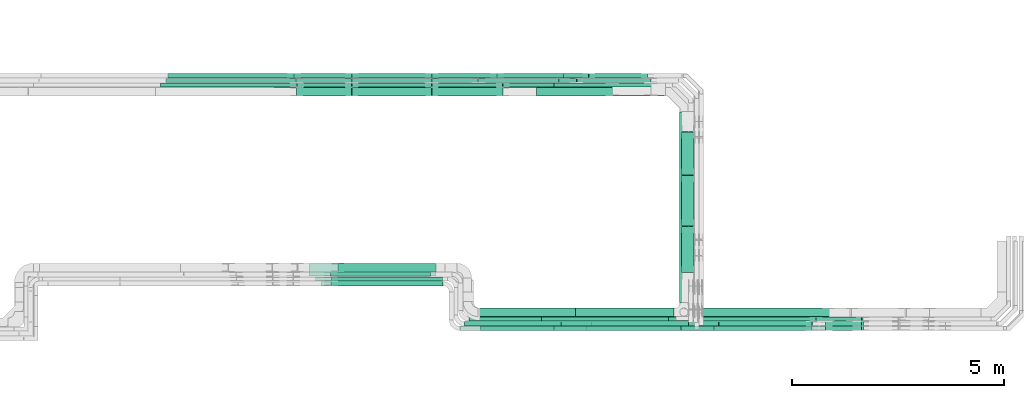
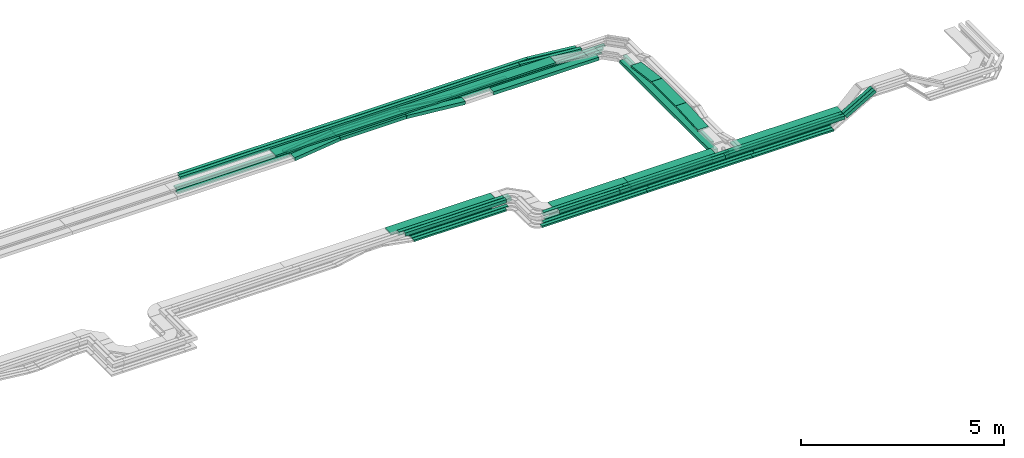
# One storey, part 4 of 33: 63 flow segments.
"""IFC2X3 building model written with IfcOpenShell, lengths in millimetres."""

from ifc_helpers import new_model, entity, si_unit, converted_unit, derived_unit, direction, frame, frame_2d, origin, origin_2d_with_axis, place, context, subcontext, project, spatial, rectangle, extrude, type_object, element, save


model = new_model("IFC2X3")

# Units and contexts
model_context = context("Model", 3, precision=0.01, world=origin(), true_north=direction((6.12303176911189e-17, 1.0)))
body_context = subcontext(model_context, "Body", "Model", "MODEL_VIEW")
ifc_project = project(units=[si_unit("LENGTHUNIT", "METRE", prefix="MILLI"), si_unit("AREAUNIT", "SQUARE_METRE"), si_unit("VOLUMEUNIT", "CUBIC_METRE"), converted_unit("PLANEANGLEUNIT", "DEGREE", entity("IfcRatioMeasure", 0.0174532925199433), si_unit("PLANEANGLEUNIT", "RADIAN"), dimensions=[0, 0, 0, 0, 0, 0, 0]), si_unit("MASSUNIT", "GRAM", prefix="KILO"), derived_unit("MASSDENSITYUNIT", [(si_unit("MASSUNIT", "GRAM", prefix="KILO"), 1), (si_unit("LENGTHUNIT", "METRE"), -3)]), derived_unit("MOMENTOFINERTIAUNIT", [(si_unit("LENGTHUNIT", "METRE"), 4)]), si_unit("TIMEUNIT", "SECOND"), si_unit("FREQUENCYUNIT", "HERTZ"), si_unit("THERMODYNAMICTEMPERATUREUNIT", "DEGREE_CELSIUS"), derived_unit("THERMALTRANSMITTANCEUNIT", [(si_unit("MASSUNIT", "GRAM", prefix="KILO"), 1), (si_unit("THERMODYNAMICTEMPERATUREUNIT", "KELVIN"), -1), (si_unit("TIMEUNIT", "SECOND"), -3)]), derived_unit("VOLUMETRICFLOWRATEUNIT", [(si_unit("LENGTHUNIT", "METRE"), 3), (si_unit("TIMEUNIT", "SECOND"), -1)]), derived_unit("MASSFLOWRATEUNIT", [(si_unit("MASSUNIT", "GRAM", prefix="KILO"), 1), (si_unit("TIMEUNIT", "SECOND"), -1)]), derived_unit("ROTATIONALFREQUENCYUNIT", [(si_unit("TIMEUNIT", "SECOND"), -1)]), si_unit("ELECTRICCURRENTUNIT", "AMPERE"), si_unit("ELECTRICVOLTAGEUNIT", "VOLT"), si_unit("POWERUNIT", "WATT"), si_unit("FORCEUNIT", "NEWTON", prefix="KILO"), si_unit("ILLUMINANCEUNIT", "LUX"), si_unit("LUMINOUSFLUXUNIT", "LUMEN"), si_unit("LUMINOUSINTENSITYUNIT", "CANDELA"), derived_unit("USERDEFINED", [(si_unit("MASSUNIT", "GRAM", prefix="KILO"), -1), (si_unit("LENGTHUNIT", "METRE"), -2), (si_unit("TIMEUNIT", "SECOND"), 3), (si_unit("LUMINOUSFLUXUNIT", "LUMEN"), 1)]), derived_unit("LINEARVELOCITYUNIT", [(si_unit("LENGTHUNIT", "METRE"), 1), (si_unit("TIMEUNIT", "SECOND"), -1)]), si_unit("PRESSUREUNIT", "PASCAL"), derived_unit("USERDEFINED", [(si_unit("LENGTHUNIT", "METRE"), -2), (si_unit("MASSUNIT", "GRAM", prefix="KILO"), 1), (si_unit("TIMEUNIT", "SECOND"), -2)]), derived_unit("LINEARFORCEUNIT", [(si_unit("MASSUNIT", "GRAM", prefix="KILO"), 1), (si_unit("LENGTHUNIT", "METRE"), 1), (si_unit("TIMEUNIT", "SECOND"), -2), (si_unit("LENGTHUNIT", "METRE"), -1)]), derived_unit("PLANARFORCEUNIT", [(si_unit("MASSUNIT", "GRAM", prefix="KILO"), 1), (si_unit("LENGTHUNIT", "METRE"), 1), (si_unit("TIMEUNIT", "SECOND"), -2), (si_unit("LENGTHUNIT", "METRE"), -2)])], contexts=[model_context])

# Site, building, storey
site_placement = place(None, frame((0.0, -0.00077364408347762, 0.0)))
site = spatial("IfcSite", under=ifc_project, at=site_placement, CompositionType="ELEMENT")
building_placement = place(site_placement, origin())
building = spatial("IfcBuilding", under=site, at=building_placement, CompositionType="ELEMENT")
storey_placement = place(building_placement, frame((0.0, 0.0, 8100.0)))
storey = spatial("IfcBuildingStorey", under=building, at=storey_placement, CompositionType="ELEMENT", Elevation=8100.0)

# Flow segments
cable_carrier_segment_type = type_object("IfcCableCarrierSegmentType", PredefinedType="CABLETRAYSEGMENT")
flow_segment_1_placement = place(storey_placement, frame((56885.3785328742, 14174.4992263554, 2549.99987589612)))
element("IfcFlowSegment", 1, at=flow_segment_1_placement, inside=storey, type_object=cable_carrier_segment_type, context=body_context, shape_type="SweptSolid", body=[
    extrude(rectangle(XDim=2998.73000000511, YDim=199.999999999998, at=frame_2d((0.0, -1.08002495835535e-12), x_axis=(1.0, 0.0))), frame((1499.36500000255, 100.0, 6.20517646780172e-05)), (0.0, 0.0, 1.0), 100.000000000001),
])
flow_segment_2_placement = place(storey_placement, frame((60470.1085349485, 9693.59904322263, 2550.0)))
element("IfcFlowSegment", 2, at=flow_segment_2_placement, inside=storey, type_object=cable_carrier_segment_type, context=body_context, shape_type="SweptSolid", body=[
    extrude(rectangle(XDim=4312.67919252471, YDim=99.9999999999946, at=frame_2d((1.13686837721616e-12, 4.33075797445781e-12), x_axis=(1.0, 0.0))), frame((50.0, 2156.33959626235, 0.0), z_axis=(0.0, 0.0, 1.0), x_axis=(0.0, -1.0, 0.0)), (0.0, 0.0, 1.0), 50.0000000000038),
])
flow_segment_3_placement = place(storey_placement, frame((59995.4041032348, 8859.97860618821, 2549.87332137859)))
element("IfcFlowSegment", 3, at=flow_segment_3_placement, inside=storey, type_object=cable_carrier_segment_type, context=body_context, shape_type="SweptSolid", body=[
    extrude(rectangle(XDim=3477.62186927145, YDim=99.9999999999989, at=frame_2d((-4.32009983342141e-12, 5.40012479177676e-13), x_axis=(1.0, 0.0))), frame((1738.81093463572, 50.0, 0.0), z_axis=(0.0, 0.0, 1.0), x_axis=(-1.0, 0.0, 0.0)), (0.0, 0.0, 1.0), 50.0000000000016),
])
flow_segment_4_placement = place(storey_placement, frame((60590.1085349485, 8969.97860618816, 2549.83876380786)))
element("IfcFlowSegment", 4, at=flow_segment_4_placement, inside=storey, type_object=cable_carrier_segment_type, context=body_context, shape_type="SweptSolid", body=[
    extrude(rectangle(XDim=3207.0799274972, YDim=200.0, at=frame_2d((4.32009983342141e-12, -5.47117906535277e-13), x_axis=(1.0, 0.0))), frame((1603.5399637486, 100.0, 0.0)), (0.0, 0.0, 1.0), 99.9999999999989),
])
flow_segment_5_placement = place(storey_placement, frame((63706.7154942404, 8749.97860609501, 2814.44529768495)))
element("IfcFlowSegment", 5, at=flow_segment_5_placement, inside=storey, type_object=cable_carrier_segment_type, context=body_context, shape_type="SweptSolid", body=[
    extrude(rectangle(XDim=99.9999999999999, YDim=99.9999999999989, at=frame_2d((4.03943545279617e-12, 0.0), x_axis=(1.0, 0.0))), frame((25.0, 50.0, 43.3012701916263), z_axis=(0.866025403784404, 0.0, 0.50000000000006), x_axis=(-0.50000000000006, 0.0, 0.866025403784404)), (0.0, 0.0, 1.0), 967.734125088294),
])
flow_segment_6_placement = place(storey_placement, frame((63705.8163687415, 8639.97859022198, 2813.92618733611)))
element("IfcFlowSegment", 6, at=flow_segment_6_placement, inside=storey, type_object=cable_carrier_segment_type, context=body_context, shape_type="SweptSolid", body=[
    extrude(rectangle(XDim=100.000000000006, YDim=99.9999999999999, at=frame_2d((-9.41469124882133e-13, 0.0), x_axis=(1.0, 0.0))), frame((25.0000652674196, 50.0, 43.3013078713806), z_axis=(0.866025403783436, 1.50728637734173e-06, 0.499999999999464), x_axis=(-0.500000000000032, 0.0, 0.86602540378442)), (0.0, 0.0, 1.0), 970.372264991507),
])
flow_segment_7_placement = place(storey_placement, frame((63476.8919979099, 8859.97860618821, 2557.60794957423)))
element("IfcFlowSegment", 7, at=flow_segment_7_placement, inside=storey, type_object=cable_carrier_segment_type, context=body_context, shape_type="SweptSolid", body=[
    extrude(rectangle(XDim=49.9999999999919, YDim=99.9999999999989, at=frame_2d((0.0, 3.75166564481333e-12), x_axis=(0.0, 1.0))), frame((12.5000000000058, 50.0, 21.6506350946079), z_axis=(0.866025403784457, 0.0, 0.499999999999968), x_axis=(0.0, 1.0, 0.0)), (0.0, 0.0, 1.0), 1241.85824337273),
])
flow_segment_8_placement = place(storey_placement, frame((55181.108534959, 8749.97860618822, 2549.86934553522)))
element("IfcFlowSegment", 8, at=flow_segment_8_placement, inside=storey, type_object=cable_carrier_segment_type, context=body_context, shape_type="SweptSolid", body=[
    extrude(rectangle(XDim=2998.73000000509, YDim=99.9999999999989, at=origin_2d_with_axis()), frame((1499.36500000254, 50.0, 0.0)), (0.0, 0.0, 1.0), 49.9999999999995),
])
flow_segment_9_placement = place(storey_placement, frame((55071.108534959, 8639.98005285077, 2548.15905189632)))
element("IfcFlowSegment", 9, at=flow_segment_9_placement, inside=storey, type_object=cable_carrier_segment_type, context=body_context, shape_type="SweptSolid", body=[
    extrude(rectangle(XDim=2998.73000000509, YDim=100.000000000001, at=origin_2d_with_axis()), frame((1499.36500000254, 50.0, 0.0)), (0.0, 0.0, 1.0), 49.9999999999995),
])
flow_segment_10_placement = place(storey_placement, frame((52023.1966318499, 9914.99937591541, 2549.87332137861)))
element("IfcFlowSegment", 10, at=flow_segment_10_placement, inside=storey, type_object=cable_carrier_segment_type, context=body_context, shape_type="SweptSolid", body=[
    extrude(rectangle(XDim=2356.3241779721, YDim=99.9999999999989, at=frame_2d((4.32009983342141e-12, 1.08357767203415e-12), x_axis=(1.0, 0.0))), frame((1178.16208898605, 50.0, 0.0), z_axis=(0.0, 0.0, 1.0), x_axis=(-1.0, 0.0, 0.0)), (0.0, 0.0, 1.0), 50.0000000000016),
])
flow_segment_11_placement = place(storey_placement, frame((52525.1367458162, 14174.499226356, 2704.57872565433)))
element("IfcFlowSegment", 11, at=flow_segment_11_placement, inside=storey, type_object=cable_carrier_segment_type, context=body_context, shape_type="SweptSolid", body=[
    extrude(rectangle(XDim=1876.86289906557, YDim=200.000000000002, at=origin_2d_with_axis()), frame((938.431449532787, 100.0, 0.0)), (0.0, 0.0, 1.0), 99.9999999999989),
])
flow_segment_12_placement = place(storey_placement, frame((57297.1754327757, 14382.2782357473, 2550.0)))
element("IfcFlowSegment", 12, at=flow_segment_12_placement, inside=storey, type_object=cable_carrier_segment_type, context=body_context, shape_type="SweptSolid", body=[
    extrude(rectangle(XDim=2796.93310217293, YDim=99.9999999999989, at=frame_2d((0.0, 1.08357767203415e-12), x_axis=(1.0, 0.0))), frame((1398.46655108647, 50.0, 0.0), z_axis=(0.0, 0.0, 1.0), x_axis=(-1.0, 0.0, 0.0)), (0.0, 0.0, 1.0), 49.9999999999995),
])
flow_segment_13_placement = place(storey_placement, frame((57517.1754327757, 14602.2782357473, 2550.0)))
element("IfcFlowSegment", 13, at=flow_segment_13_placement, inside=storey, type_object=cable_carrier_segment_type, context=body_context, shape_type="SweptSolid", body=[
    extrude(rectangle(XDim=2796.93310217294, YDim=99.9999999999989, at=frame_2d((4.43378667114303e-12, 1.08357767203415e-12), x_axis=(1.0, 0.0))), frame((1398.46655108647, 50.0, 0.0), z_axis=(0.0, 0.0, 1.0), x_axis=(-1.0, 0.0, 0.0)), (0.0, 0.0, 1.0), 50.0000000000016),
])
flow_segment_14_placement = place(storey_placement, frame((52523.6443090049, 14382.2782357473, 2704.02706365648)))
element("IfcFlowSegment", 14, at=flow_segment_14_placement, inside=storey, type_object=cable_carrier_segment_type, context=body_context, shape_type="SweptSolid", body=[
    extrude(rectangle(XDim=1879.49381672388, YDim=99.9999999999989, at=frame_2d((-4.32009983342141e-12, 0.0), x_axis=(1.0, 0.0))), frame((939.746908361942, 50.0, 0.0), z_axis=(0.0, 0.0, 1.0), x_axis=(-1.0, 0.0, 0.0)), (0.0, 0.0, 1.0), 50.0000000000016),
])
flow_segment_15_placement = place(storey_placement, frame((52525.6197642825, 14492.2782357474, 2704.02285746088)))
element("IfcFlowSegment", 15, at=flow_segment_15_placement, inside=storey, type_object=cable_carrier_segment_type, context=body_context, shape_type="SweptSolid", body=[
    extrude(rectangle(XDim=1881.17742834909, YDim=99.9999999999989, at=origin_2d_with_axis()), frame((940.588714174547, 50.0, 0.0), z_axis=(0.0, 0.0, 1.0), x_axis=(-1.0, 0.0, 0.0)), (0.0, 0.0, 1.0), 50.0000000000016),
])
flow_segment_16_placement = place(storey_placement, frame((52523.5605083253, 14602.2782357473, 2704.50214316131)))
element("IfcFlowSegment", 16, at=flow_segment_16_placement, inside=storey, type_object=cable_carrier_segment_type, context=body_context, shape_type="SweptSolid", body=[
    extrude(rectangle(XDim=1879.86643624629, YDim=99.9999999999989, at=origin_2d_with_axis()), frame((939.933218123143, 50.0, 0.0), z_axis=(0.0, 0.0, 1.0), x_axis=(-1.0, 0.0, 0.0)), (0.0, 0.0, 1.0), 50.0000000000016),
])
flow_segment_17_placement = place(storey_placement, frame((48186.70401646, 14602.2782357471, 2855.0)))
element("IfcFlowSegment", 17, at=flow_segment_17_placement, inside=storey, type_object=cable_carrier_segment_type, context=body_context, shape_type="SweptSolid", body=[
    extrude(rectangle(XDim=9916.000468824, YDim=99.9999999999989, at=frame_2d((-4.09272615797818e-12, 0.0), x_axis=(1.0, 0.0))), frame((4958.00023441201, 50.0, 0.0), z_axis=(0.0, 0.0, 1.0), x_axis=(-1.0, 0.0, 0.0)), (0.0, 0.0, 1.0), 99.9999999999989),
])
flow_segment_18_placement = place(storey_placement, frame((48139.5712463111, 14492.2782357471, 2855.0)))
element("IfcFlowSegment", 18, at=flow_segment_18_placement, inside=storey, type_object=cable_carrier_segment_type, context=body_context, shape_type="SweptSolid", body=[
    extrude(rectangle(XDim=9680.19408379606, YDim=99.9999999999989, at=frame_2d((-4.54747350886464e-12, -1.08357767203415e-12), x_axis=(1.0, 0.0))), frame((4840.09704189803, 50.0, 0.0), z_axis=(0.0, 0.0, 1.0), x_axis=(-1.0, 0.0, 0.0)), (0.0, 0.0, 1.0), 100.000000000001),
])
flow_segment_19_placement = place(storey_placement, frame((58105.0986360754, 14602.2782357478, 2715.71842327015)))
element("IfcFlowSegment", 19, at=flow_segment_19_placement, inside=storey, type_object=cable_carrier_segment_type, context=body_context, shape_type="SweptSolid", body=[
    extrude(rectangle(XDim=99.9999999999978, YDim=99.9999999999989, at=frame_2d((0.0, 0.0), x_axis=(0.0, 1.0))), frame((4.98927268597879, 50.0, 188.912276004697), z_axis=(0.995008976454976, 0.0, -0.099785453719578), x_axis=(0.0, 1.0, 0.0)), (0.0, 0.0, 1.0), 1394.61035646541),
])
flow_segment_20_placement = place(storey_placement, frame((54405.8210953628, 14602.2782357473, 2550.36930072502)))
element("IfcFlowSegment", 20, at=flow_segment_20_placement, inside=storey, type_object=cable_carrier_segment_type, context=body_context, shape_type="SweptSolid", body=[
    extrude(rectangle(XDim=50.0000000000019, YDim=99.9999999999989, at=frame_2d((0.0, 0.0), x_axis=(0.0, 1.0))), frame((2.49463634299373, 50.0, 178.888317299769), z_axis=(0.995008976454959, 0.0, -0.0997854537197453), x_axis=(0.0, 1.0, 0.0)), (0.0, 0.0, 1.0), 1543.44232698593),
])
flow_segment_21_placement = place(storey_placement, frame((51155.2953473547, 14602.2782357473, 2549.32790756927)))
element("IfcFlowSegment", 21, at=flow_segment_21_placement, inside=storey, type_object=cable_carrier_segment_type, context=body_context, shape_type="SweptSolid", body=[
    extrude(rectangle(XDim=49.9999999999997, YDim=99.9999999999989, at=frame_2d((0.0, 0.0), x_axis=(0.0, 1.0))), frame((2.8312528840519, 50.0, 24.8391627698387), z_axis=(0.993566510793554, 0.0, 0.113250115362077), x_axis=(0.0, 1.0, 0.0)), (0.0, 0.0, 1.0), 1368.9632988374),
])
flow_segment_22_placement = place(storey_placement, frame((57822.0798542568, 14492.2782357478, 2715.47101416247)))
element("IfcFlowSegment", 22, at=flow_segment_22_placement, inside=storey, type_object=cable_carrier_segment_type, context=body_context, shape_type="SweptSolid", body=[
    extrude(rectangle(XDim=99.9999999999997, YDim=99.9999999999989, at=frame_2d((0.0, 0.0), x_axis=(0.0, 1.0))), frame((3.97103707300582, 50.0, 189.278989024141), z_axis=(0.996841183853238, 0.0, -0.0794207414601167), x_axis=(0.0, 1.0, 0.0)), (0.0, 0.0, 1.0), 1755.67398727266),
])
flow_segment_23_placement = place(storey_placement, frame((51204.636435937, 14492.2782357474, 2548.83844201225)))
element("IfcFlowSegment", 23, at=flow_segment_23_placement, inside=storey, type_object=cable_carrier_segment_type, context=body_context, shape_type="SweptSolid", body=[
    extrude(rectangle(XDim=50.0000000000001, YDim=99.9999999999989, at=frame_2d((0.0, 2.16715534406831e-12), x_axis=(1.0, 0.0))), frame((2.9323989121873, 50.0, 24.8274250904077), z_axis=(0.993097003616306, 0.0, 0.117295956487492), x_axis=(-0.117295956487492, 0.0, 0.993097003616306)), (0.0, 0.0, 1.0), 1321.78049567335),
])
flow_segment_24_placement = place(storey_placement, frame((54409.34655598, 14492.2782357474, 2550.67005620055)))
element("IfcFlowSegment", 24, at=flow_segment_24_placement, inside=storey, type_object=cable_carrier_segment_type, context=body_context, shape_type="SweptSolid", body=[
    extrude(rectangle(XDim=50.0000000000019, YDim=99.9999999999989, at=frame_2d((-2.16715534406831e-12, 0.0), x_axis=(0.0, 1.0))), frame((3.49489366633807, 50.0, 177.92823601063), z_axis=(0.990180361963206, 0.0, -0.139795746653517), x_axis=(0.0, 1.0, 0.0)), (0.0, 0.0, 1.0), 1095.69661901961),
])
flow_segment_25_placement = place(storey_placement, frame((57407.1754327757, 14492.2782357474, 2550.0)))
element("IfcFlowSegment", 25, at=flow_segment_25_placement, inside=storey, type_object=cable_carrier_segment_type, context=body_context, shape_type="SweptSolid", body=[
    extrude(rectangle(XDim=2796.93310217294, YDim=99.9999999999989, at=frame_2d((4.43378667114303e-12, -1.08357767203415e-12), x_axis=(1.0, 0.0))), frame((1398.46655108647, 50.0, 0.0), z_axis=(0.0, 0.0, 1.0), x_axis=(-1.0, 0.0, 0.0)), (0.0, 0.0, 1.0), 50.0000000000016),
])
flow_segment_26_placement = place(storey_placement, frame((54405.4997930208, 14382.2782357473, 2550.31781572483)))
element("IfcFlowSegment", 26, at=flow_segment_26_placement, inside=storey, type_object=cable_carrier_segment_type, context=body_context, shape_type="SweptSolid", body=[
    extrude(rectangle(XDim=49.9999999999988, YDim=99.9999999999989, at=origin_2d_with_axis()), frame((2.28661860515408, 50.0, 178.49622432745), z_axis=(0.995808315172805, 0.0, -0.0914647442061654), x_axis=(0.0914647442061654, 0.0, 0.995808315172805)), (0.0, 0.0, 1.0), 1679.34670108359),
])
flow_segment_27_placement = place(storey_placement, frame((51225.8368061819, 14382.2782357473, 2549.38241939669)))
element("IfcFlowSegment", 27, at=flow_segment_27_placement, inside=storey, type_object=cable_carrier_segment_type, context=body_context, shape_type="SweptSolid", body=[
    extrude(rectangle(XDim=50.0000000000011, YDim=99.9999999999989, at=frame_2d((0.0, 0.0), x_axis=(0.0, 1.0))), frame((2.97427394018584, 50.0, 24.8224433633911), z_axis=(0.992897734535622, 0.0, 0.118970957607431), x_axis=(0.0, 1.0, 0.0)), (0.0, 0.0, 1.0), 1298.61326955361),
])
flow_segment_28_placement = place(storey_placement, frame((54404.3625850316, 14174.499226356, 2550.53084253341)))
element("IfcFlowSegment", 28, at=flow_segment_28_placement, inside=storey, type_object=cable_carrier_segment_type, context=body_context, shape_type="SweptSolid", body=[
    extrude(rectangle(XDim=99.999999999999, YDim=200.000000000002, at=frame_2d((0.0, -2.16715534406831e-12), x_axis=(1.0, 0.0))), frame((4.58952255518666, 100.0, 203.728123319209), z_axis=(0.995778345359133, 0.0, -0.0917904511037341), x_axis=(0.0917904511037341, 0.0, 0.995778345359133)), (0.0, 0.0, 1.0), 1677.07211589127),
])
flow_segment_29_placement = place(storey_placement, frame((51219.7158012218, 14174.499226356, 2549.7345905369)))
element("IfcFlowSegment", 29, at=flow_segment_29_placement, inside=storey, type_object=cable_carrier_segment_type, context=body_context, shape_type="SweptSolid", body=[
    extrude(rectangle(XDim=100.0, YDim=200.000000000002, at=frame_2d((0.0, 0.0), x_axis=(0.0, 1.0))), frame((5.94854788036303, 100.0, 49.6448867267822), z_axis=(0.992897734535643, 0.0, 0.11897095760726), x_axis=(0.0, 1.0, 0.0)), (0.0, 0.0, 1.0), 1300.29007254466),
])
flow_segment_30_placement = place(storey_placement, frame((60465.0369295573, 8749.97798436678, 2800.01131884826)))
element("IfcFlowSegment", 30, at=flow_segment_30_placement, inside=storey, type_object=cable_carrier_segment_type, context=body_context, shape_type="SweptSolid", body=[
    extrude(rectangle(XDim=3237.81245084928, YDim=99.9999999999677, at=frame_2d((4.32009983342141e-12, 0.0), x_axis=(1.0, 0.0))), frame((1618.90622542461, 50.0, 0.00193993403595982), z_axis=(8.14261929601907e-07, 1.24344065765253e-05, 1.0), x_axis=(-1.0, 0.0, 8.14261929710101e-07)), (0.0, 0.0, 1.0), 99.9999999999661),
])
flow_segment_31_placement = place(storey_placement, frame((60292.6896649915, 8639.9773713794, 2799.49164816933)))
element("IfcFlowSegment", 31, at=flow_segment_31_placement, inside=storey, type_object=cable_carrier_segment_type, context=body_context, shape_type="SweptSolid", body=[
    extrude(rectangle(XDim=3409.26074361394, YDim=99.9999999999995, at=frame_2d((0.0, -5.43565192856477e-13), x_axis=(1.0, 0.0))), frame((1704.63037180697, 50.002437699898, 0.00121885741024812), z_axis=(0.0, -2.43771475119276e-05, 1.0), x_axis=(-1.0, 0.0, 0.0)), (0.0, 0.0, 1.0), 100.000000000002),
])
flow_segment_32_placement = place(storey_placement, frame((48074.4462970112, 14602.2782357473, 2548.86724903676)))
element("IfcFlowSegment", 32, at=flow_segment_32_placement, inside=storey, type_object=cable_carrier_segment_type, context=body_context, shape_type="SweptSolid", body=[
    extrude(rectangle(XDim=3078.40248337126, YDim=99.9999999999989, at=frame_2d((-4.32009983342141e-12, 1.08357767203415e-12), x_axis=(1.0, 0.0))), frame((1539.20124168563, 50.0, 0.0)), (0.0, 0.0, 1.0), 50.0000000000016),
])
flow_segment_33_placement = place(storey_placement, frame((55948.9434888315, 14602.2782357473, 2550.0)))
element("IfcFlowSegment", 33, at=flow_segment_33_placement, inside=storey, type_object=cable_carrier_segment_type, context=body_context, shape_type="SweptSolid", body=[
    extrude(rectangle(XDim=1565.69194395434, YDim=99.9999999999989, at=frame_2d((0.0, 1.08357767203415e-12), x_axis=(1.0, 0.0))), frame((782.84597197717, 50.0, 0.0), z_axis=(0.0, 0.0, 1.0), x_axis=(-1.0, 0.0, 0.0)), (0.0, 0.0, 1.0), 50.0000000000016),
])
flow_segment_34_placement = place(storey_placement, frame((48068.9694604464, 14492.2782357474, 2548.34838425104)))
element("IfcFlowSegment", 34, at=flow_segment_34_placement, inside=storey, type_object=cable_carrier_segment_type, context=body_context, shape_type="SweptSolid", body=[
    extrude(rectangle(XDim=3133.20469466123, YDim=99.9999999999989, at=frame_2d((0.0, -1.08357767203415e-12), x_axis=(1.0, 0.0))), frame((1566.60234733062, 50.0, 0.0)), (0.0, 0.0, 1.0), 50.0000000000016),
])
flow_segment_35_placement = place(storey_placement, frame((58182.3785349539, 8749.97860618822, 2549.86934553522)))
element("IfcFlowSegment", 35, at=flow_segment_35_placement, inside=storey, type_object=cable_carrier_segment_type, context=body_context, shape_type="SweptSolid", body=[
    extrude(rectangle(XDim=2997.46000001017, YDim=99.9999999999989, at=origin_2d_with_axis()), frame((1498.73000000508, 50.0, 0.0)), (0.0, 0.0, 1.0), 50.0000000000016),
])
flow_segment_36_placement = place(storey_placement, frame((61182.3785349539, 8749.97860618822, 2549.86934553517)))
element("IfcFlowSegment", 36, at=flow_segment_36_placement, inside=storey, type_object=cable_carrier_segment_type, context=body_context, shape_type="SweptSolid", body=[
    extrude(rectangle(XDim=2203.98504170558, YDim=99.9999999999989, at=frame_2d((0.0, -5.40012479177676e-13), x_axis=(1.0, 0.0))), frame((1101.99252085279, 50.0, 0.0)), (0.0, 0.0, 1.0), 50.0000000000016),
])
flow_segment_37_placement = place(storey_placement, frame((55503.8229814838, 14492.2782357474, 2550.0)))
element("IfcFlowSegment", 37, at=flow_segment_37_placement, inside=storey, type_object=cable_carrier_segment_type, context=body_context, shape_type="SweptSolid", body=[
    extrude(rectangle(XDim=1900.81245130203, YDim=99.9999999999989, at=frame_2d((0.0, -1.08357767203415e-12), x_axis=(1.0, 0.0))), frame((950.406225651017, 50.0, 0.0), z_axis=(0.0, 0.0, 1.0), x_axis=(-1.0, 0.0, 0.0)), (0.0, 0.0, 1.0), 50.0000000000016),
])
flow_segment_38_placement = place(storey_placement, frame((55501.108534959, 8969.97860618817, 2549.83876380786)))
element("IfcFlowSegment", 38, at=flow_segment_38_placement, inside=storey, type_object=cable_carrier_segment_type, context=body_context, shape_type="SweptSolid", body=[
    extrude(rectangle(XDim=2294.80992749182, YDim=200.0, at=frame_2d((8.64019966684282e-12, 0.0), x_axis=(1.0, 0.0))), frame((1147.40496374592, 100.0, 0.0), z_axis=(0.0, 0.0, 1.0), x_axis=(-1.0, 0.0, 0.0)), (0.0, 0.0, 1.0), 99.9999999999989),
])
flow_segment_39_placement = place(storey_placement, frame((60730.1085349485, 8869.97860618826, 2788.91979567563)))
element("IfcFlowSegment", 39, at=flow_segment_39_placement, inside=storey, type_object=cable_carrier_segment_type, context=body_context, shape_type="SweptSolid", body=[
    extrude(rectangle(XDim=3049.73475703477, YDim=300.000000000001, at=frame_2d((4.32009983342141e-12, 1.08002495835535e-12), x_axis=(1.0, 0.0))), frame((1524.86737851739, 150.0, 0.0)), (0.0, 0.0, 1.0), 50.0000000000016),
])
flow_segment_40_placement = place(storey_placement, frame((55543.5603119385, 8869.97860618826, 2788.91979567565)))
element("IfcFlowSegment", 40, at=flow_segment_40_placement, inside=storey, type_object=cable_carrier_segment_type, context=body_context, shape_type="SweptSolid", body=[
    extrude(rectangle(XDim=2134.15215708081, YDim=300.000000000001, at=frame_2d((0.0, 5.40012479177676e-13), x_axis=(1.0, 0.0))), frame((1067.07607854041, 150.0, 0.0), z_axis=(0.0, 0.0, 1.0), x_axis=(-1.0, 0.0, 0.0)), (0.0, 0.0, 1.0), 50.0000000000016),
])
flow_segment_41_placement = place(storey_placement, frame((51509.9507246394, 9924.99937591544, 2789.72547693571)))
element("IfcFlowSegment", 41, at=flow_segment_41_placement, inside=storey, type_object=cable_carrier_segment_type, context=body_context, shape_type="SweptSolid", body=[
    extrude(rectangle(XDim=2997.46000001017, YDim=300.000000000001, at=frame_2d((-4.32009983342141e-12, 0.0), x_axis=(1.0, 0.0))), frame((1498.7291737748, 150.0, 1.57371901689521), z_axis=(0.0010500350409279, 0.0, 0.999999448713054), x_axis=(0.999999448713054, 0.0, -0.0010500350409279)), (0.0, 0.0, 1.0), 50.0000000000008),
])
flow_segment_42_placement = place(storey_placement, frame((51790.3689019505, 9695.00067454255, 2799.27707434705)))
element("IfcFlowSegment", 42, at=flow_segment_42_placement, inside=storey, type_object=cable_carrier_segment_type, context=body_context, shape_type="SweptSolid", body=[
    extrude(rectangle(XDim=2878.73960950955, YDim=99.9999999999989, at=origin_2d_with_axis()), frame((1439.36980475461, 50.0, 0.000676485196879639)), (0.0, 0.0, 1.0), 100.000000000001),
])
flow_segment_43_placement = place(storey_placement, frame((48006.519147824, 14382.2782357473, 2548.87992610401)))
element("IfcFlowSegment", 43, at=flow_segment_43_placement, inside=storey, type_object=cable_carrier_segment_type, context=body_context, shape_type="SweptSolid", body=[
    extrude(rectangle(XDim=3216.84887679289, YDim=99.9999999999989, at=frame_2d((4.32009983342141e-12, 1.08357767203415e-12), x_axis=(1.0, 0.0))), frame((1608.42443839644, 50.0, 0.0)), (0.0, 0.0, 1.0), 50.0000000000016),
])
flow_segment_44_placement = place(storey_placement, frame((56995.4041032348, 8859.97860618821, 2549.87332137862)))
element("IfcFlowSegment", 44, at=flow_segment_44_placement, inside=storey, type_object=cable_carrier_segment_type, context=body_context, shape_type="SweptSolid", body=[
    extrude(rectangle(XDim=2997.46000001017, YDim=100.000000000001, at=frame_2d((0.0, -1.08357767203415e-12), x_axis=(1.0, 0.0))), frame((1498.73000000508, 50.0, 0.0), z_axis=(0.0, 0.0, 1.0), x_axis=(-1.0, 0.0, 0.0)), (0.0, 0.0, 1.0), 50.0000000000016),
])
flow_segment_45_placement = place(storey_placement, frame((55291.108534959, 8859.97860618821, 2549.87332137862)))
element("IfcFlowSegment", 45, at=flow_segment_45_placement, inside=storey, type_object=cable_carrier_segment_type, context=body_context, shape_type="SweptSolid", body=[
    extrude(rectangle(XDim=1701.75556828602, YDim=100.000000000001, at=frame_2d((4.32009983342141e-12, -1.08357767203415e-12), x_axis=(1.0, 0.0))), frame((850.877784143004, 50.0, 0.0), z_axis=(0.0, 0.0, 1.0), x_axis=(-1.0, 0.0, 0.0)), (0.0, 0.0, 1.0), 50.0000000000016),
])
flow_segment_46_placement = place(storey_placement, frame((58072.3785349539, 8639.98005285078, 2548.15905189632)))
element("IfcFlowSegment", 46, at=flow_segment_46_placement, inside=storey, type_object=cable_carrier_segment_type, context=body_context, shape_type="SweptSolid", body=[
    extrude(rectangle(XDim=2997.46000001016, YDim=100.000000000001, at=frame_2d((-4.32009983342141e-12, 0.0), x_axis=(1.0, 0.0))), frame((1498.73000000508, 50.0, 0.0)), (0.0, 0.0, 1.0), 50.0000000000016),
])
flow_segment_47_placement = place(storey_placement, frame((61072.3785349539, 8639.98005285077, 2548.1590518963)))
element("IfcFlowSegment", 47, at=flow_segment_47_placement, inside=storey, type_object=cable_carrier_segment_type, context=body_context, shape_type="SweptSolid", body=[
    extrude(rectangle(XDim=2311.02485014284, YDim=100.000000000001, at=frame_2d((0.0, 5.43565192856477e-13), x_axis=(1.0, 0.0))), frame((1155.51242507142, 50.0, 0.0)), (0.0, 0.0, 1.0), 50.0000000000016),
])
flow_segment_48_placement = place(storey_placement, frame((56084.7421065201, 14382.2782357473, 2550.0)))
element("IfcFlowSegment", 48, at=flow_segment_48_placement, inside=storey, type_object=cable_carrier_segment_type, context=body_context, shape_type="SweptSolid", body=[
    extrude(rectangle(XDim=1209.89332626571, YDim=99.9999999999989, at=origin_2d_with_axis()), frame((604.946663132853, 50.0, 0.0), z_axis=(0.0, 0.0, 1.0), x_axis=(-1.0, 0.0, 0.0)), (0.0, 0.0, 1.0), 50.0000000000016),
])
flow_segment_49_placement = place(storey_placement, frame((57465.0369260851, 8749.97860607146, 2800.01457923683)))
element("IfcFlowSegment", 49, at=flow_segment_49_placement, inside=storey, type_object=cable_carrier_segment_type, context=body_context, shape_type="SweptSolid", body=[
    extrude(rectangle(XDim=2997.46000001017, YDim=100.000000000001, at=frame_2d((4.32009983342141e-12, -5.43565192856477e-13), x_axis=(1.0, 0.0))), frame((1498.7300000045, 50.0, 0.00132448791075035), z_axis=(8.83740173844426e-07, 0.0, 1.0), x_axis=(-1.0, 0.0, 8.83740173844426e-07)), (0.0, 0.0, 1.0), 99.999999999999),
])
flow_segment_50_placement = place(storey_placement, frame((55181.3346889171, 8749.97860603508, 2800.01723045735)))
element("IfcFlowSegment", 50, at=flow_segment_50_placement, inside=storey, type_object=cable_carrier_segment_type, context=body_context, shape_type="SweptSolid", body=[
    extrude(rectangle(XDim=2281.16223717898, YDim=99.9999999999989, at=frame_2d((4.32009983342141e-12, -1.08357767203415e-12), x_axis=(1.0, 0.0))), frame((1140.58111858905, 50.0, 0.00100797735973401), z_axis=(8.83740178044858e-07, 0.0, 1.0), x_axis=(-1.0, 0.0, 8.83740178044858e-07)), (0.0, 0.0, 1.0), 100.000000000001),
])
flow_segment_51_placement = place(storey_placement, frame((51664.8615179636, 9804.99937591547, 2799.81029738234)))
element("IfcFlowSegment", 51, at=flow_segment_51_placement, inside=storey, type_object=cable_carrier_segment_type, context=body_context, shape_type="SweptSolid", body=[
    extrude(rectangle(XDim=2997.46000001016, YDim=99.9999999999989, at=origin_2d_with_axis()), frame((1498.72999965033, 50.0, 0.0326091558266285)), (0.0, 0.0, 1.0), 100.000000000002),
])
flow_segment_52_placement = place(storey_placement, frame((57292.6896649915, 8639.97859022192, 2799.49286701191)))
element("IfcFlowSegment", 52, at=flow_segment_52_placement, inside=storey, type_object=cable_carrier_segment_type, context=body_context, shape_type="SweptSolid", body=[
    extrude(rectangle(XDim=2997.46000001017, YDim=99.9999999999989, at=origin_2d_with_axis()), frame((1498.73000000508, 50.0, 0.0), z_axis=(0.0, 0.0, 1.0), x_axis=(-1.0, 0.0, 0.0)), (0.0, 0.0, 1.0), 99.9999999999989),
])
flow_segment_53_placement = place(storey_placement, frame((55563.270115285, 8639.97859022192, 2799.4928670119)))
element("IfcFlowSegment", 53, at=flow_segment_53_placement, inside=storey, type_object=cable_carrier_segment_type, context=body_context, shape_type="SweptSolid", body=[
    extrude(rectangle(XDim=1726.87954971664, YDim=99.9999999999989, at=frame_2d((-4.32009983342141e-12, 0.0), x_axis=(1.0, 0.0))), frame((863.439774858324, 50.0, 0.0), z_axis=(0.0, 0.0, 1.0), x_axis=(-1.0, 0.0, 0.0)), (0.0, 0.0, 1.0), 99.9999999999989),
])
flow_segment_54_placement = place(storey_placement, frame((50684.7684883553, 14182.2782357481, 2854.49733895755)))
element("IfcFlowSegment", 54, at=flow_segment_54_placement, inside=storey, type_object=cable_carrier_segment_type, context=body_context, shape_type="SweptSolid", body=[
    extrude(rectangle(XDim=7981.68636382829, YDim=300.000000000001, at=frame_2d((-4.32009983342141e-12, -1.08002495835535e-12), x_axis=(1.0, 0.0))), frame((3990.84318191414, 150.0, 0.0), z_axis=(0.0, 0.0, 1.0), x_axis=(-1.0, 0.0, 0.0)), (0.0, 0.0, 1.0), 50.0000000000016),
])
flow_segment_55_placement = place(storey_placement, frame((60300.1085349485, 11101.1128972283, 2849.70764721446)))
element("IfcFlowSegment", 55, at=flow_segment_55_placement, inside=storey, type_object=cable_carrier_segment_type, context=body_context, shape_type="SweptSolid", body=[
    extrude(rectangle(XDim=1194.27294573959, YDim=300.000000000001, at=origin_2d_with_axis()), frame((150.0, 597.136472869794, 0.0), z_axis=(0.0, 0.0, 1.0), x_axis=(0.0, -1.0, 0.0)), (0.0, 0.0, 1.0), 50.0000000000016),
])
flow_segment_56_placement = place(storey_placement, frame((60300.1085349485, 12297.8971885312, 2715.30437917673)))
element("IfcFlowSegment", 56, at=flow_segment_56_placement, inside=storey, type_object=cable_carrier_segment_type, context=body_context, shape_type="SweptSolid", body=[
    extrude(rectangle(XDim=49.9999999999993, YDim=1032.95661141411, at=frame_2d((0.0, 0.0), x_axis=(0.0, 1.0))), frame((0.0, 515.347326776083, 91.9076877071692), z_axis=(1.0, 0.0, 0.0), x_axis=(0.0, -0.991519700782224, 0.129956465636495)), (0.0, 0.0, 1.0), 300.000000000001),
])
flow_segment_57_placement = place(storey_placement, frame((60260.1085349486, 9299.97698701316, 2549.83876383407)))
element("IfcFlowSegment", 57, at=flow_segment_57_placement, inside=storey, type_object=cable_carrier_segment_type, context=body_context, shape_type="SweptSolid", body=[
    extrude(rectangle(XDim=4498.52062277624, YDim=200.000000000007, at=frame_2d((0.0, -4.33431068813661e-12), x_axis=(1.0, 0.0))), frame((100.0, 2249.26354855874, 0.0728389214051617), z_axis=(0.0, -3.23835000490124e-05, 1.0), x_axis=(0.0, 1.0, 3.23835000490124e-05)), (0.0, 0.0, 1.0), 100.000000000001),
])
flow_segment_58_placement = place(storey_placement, frame((57798.4584624407, 8969.97860618817, 2549.83876380786)))
element("IfcFlowSegment", 58, at=flow_segment_58_placement, inside=storey, type_object=cable_carrier_segment_type, context=body_context, shape_type="SweptSolid", body=[
    extrude(rectangle(XDim=2331.65007250791, YDim=200.0, at=origin_2d_with_axis()), frame((1165.82503625396, 100.0, 0.0)), (0.0, 0.0, 1.0), 99.9999999999989),
])
flow_segment_59_placement = place(storey_placement, frame((57680.2524690091, 8869.97860618826, 2788.91979567565)))
element("IfcFlowSegment", 59, at=flow_segment_59_placement, inside=storey, type_object=cable_carrier_segment_type, context=body_context, shape_type="SweptSolid", body=[
    extrude(rectangle(XDim=2489.8560659394, YDim=300.000000000001, at=frame_2d((-4.32009983342141e-12, 0.0), x_axis=(1.0, 0.0))), frame((1244.92803296971, 150.0, 0.0)), (0.0, 0.0, 1.0), 50.0000000000016),
])
flow_segment_60_placement = place(storey_placement, frame((60300.1085349485, 10006.3935550384, 2789.05857916589)))
element("IfcFlowSegment", 60, at=flow_segment_60_placement, inside=storey, type_object=cable_carrier_segment_type, context=body_context, shape_type="SweptSolid", body=[
    extrude(rectangle(XDim=49.9999999999986, YDim=1091.40617027104, at=frame_2d((-5.6843418860808e-14, -1.08002495835535e-12), x_axis=(0.0, 1.0))), frame((0.0, 546.249415830828, 55.2551422791825), z_axis=(1.0, 0.0, 0.0), x_axis=(0.0, -0.998457956531639, -0.0555131429362733)), (0.0, 0.0, 1.0), 300.000000000001),
])
flow_segment_61_placement = place(storey_placement, frame((52043.7224289651, 9804.99937599438, 2549.88064072271)))
element("IfcFlowSegment", 61, at=flow_segment_61_placement, inside=storey, type_object=cable_carrier_segment_type, context=body_context, shape_type="SweptSolid", body=[
    extrude(rectangle(XDim=2735.38470576596, YDim=99.9999998421082, at=frame_2d((4.32009983342141e-12, 0.0), x_axis=(1.0, 0.0))), frame((1367.6923507235, 50.0, 0.0768568834136829)), (0.0, 0.0, 1.0), 49.9999999210567),
])
flow_segment_62_placement = place(storey_placement, frame((52033.7757444132, 9694.99937600128, 2548.17083100622)))
element("IfcFlowSegment", 62, at=flow_segment_62_placement, inside=storey, type_object=cable_carrier_segment_type, context=body_context, shape_type="SweptSolid", body=[
    extrude(rectangle(XDim=2635.33133036341, YDim=99.9999998282887, at=frame_2d((-4.32009983342141e-12, -1.08002495835535e-12), x_axis=(1.0, 0.0))), frame((1317.66566291914, 50.0, 0.0772179878278166)), (0.0, 0.0, 1.0), 49.9999999141444),
])
flow_segment_63_placement = place(storey_placement, frame((52195.6894958864, 10024.9993761201, 2549.85482421988)))
element("IfcFlowSegment", 63, at=flow_segment_63_placement, inside=storey, type_object=cable_carrier_segment_type, context=body_context, shape_type="SweptSolid", body=[
    extrude(rectangle(XDim=2803.41584608065, YDim=199.999999590592, at=frame_2d((0.0, 1.08713038571295e-12), x_axis=(1.0, 0.0))), frame((1401.70792017098, 99.9999997953002, 0.0896881268538664), z_axis=(6.39848897038753e-05, 0.0, 0.999999997952967), x_axis=(0.999999997952967, 0.0, -6.39848897038753e-05)), (0.0, 0.0, 1.0), 99.9999997952961),
])

save(model, "model.ifc")
